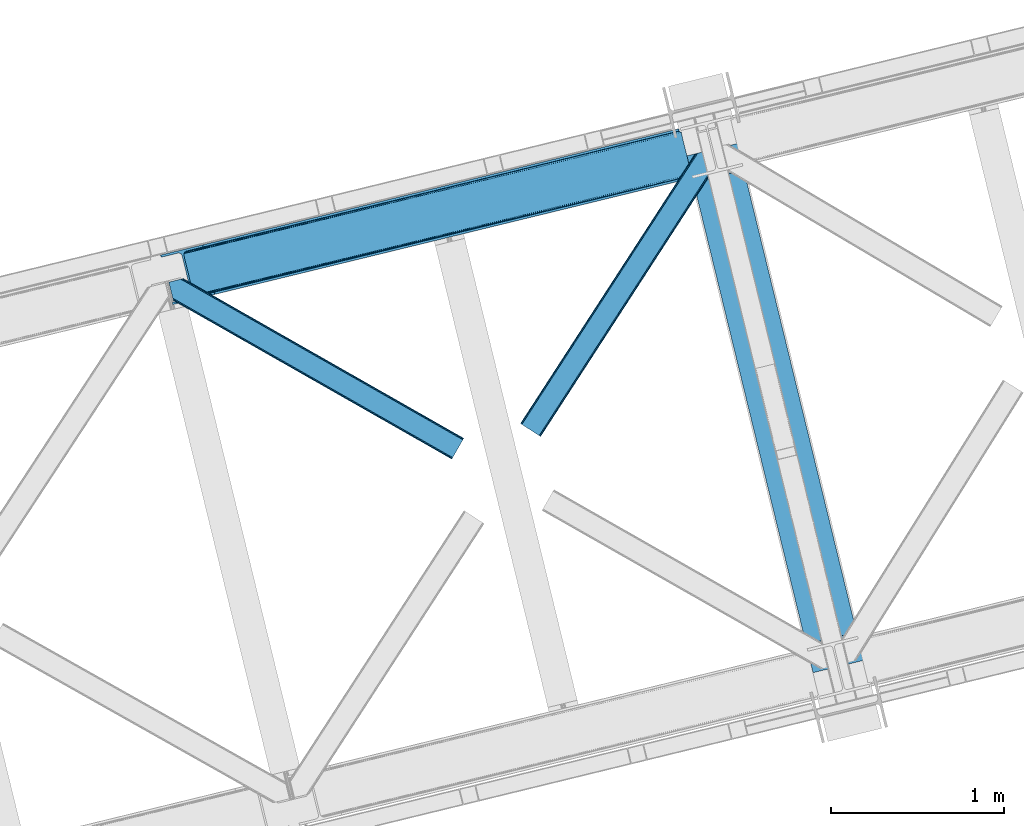
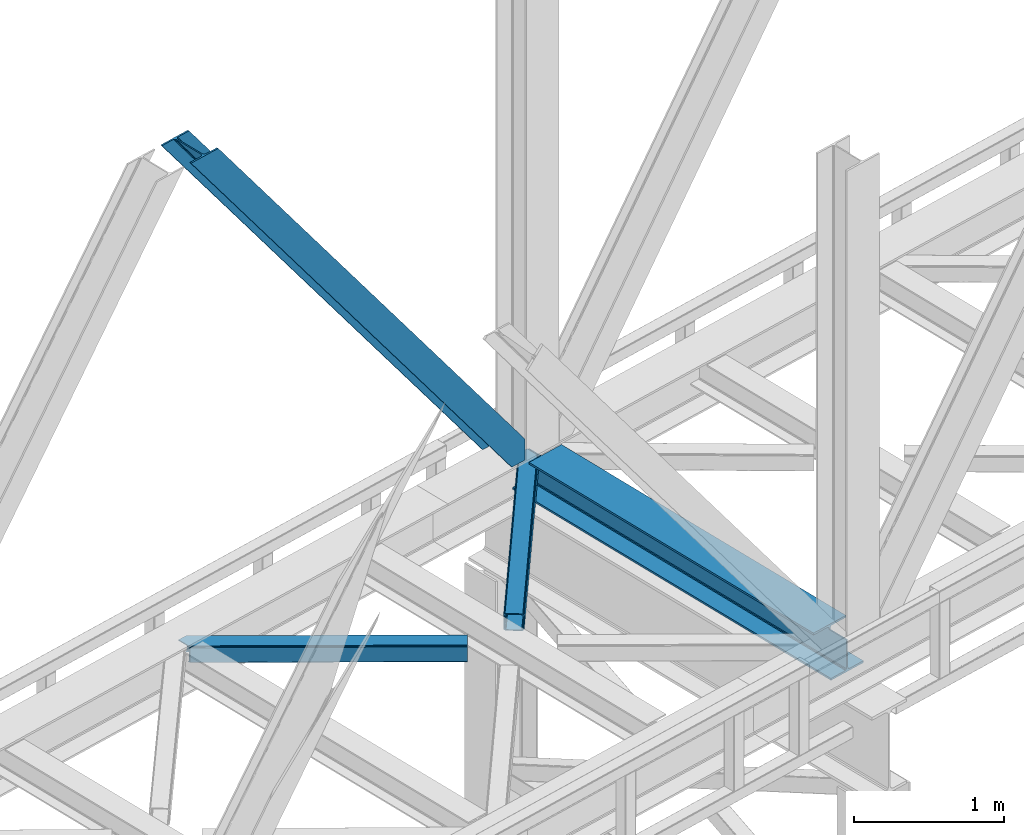
# One storey, part 55 of 93: 3 members, 1 beam.
"""IFC4 building model written with IfcOpenShell, lengths in millimetres."""

from ifc_helpers import new_model, entity, si_unit, converted_unit, derived_unit, direction, frame, origin, place, context, subcontext, project, spatial, triangles, polygons, material, type_object, element, save


model = new_model("IFC4")

# Units and contexts
model_context = context("Model", 3, precision=0.01, world=origin(), true_north=direction((6.12303176911189e-17, 1.0)))
plan_context = context("Plan", 3, precision=0.01, world=origin(), true_north=direction((6.12303176911189e-17, 1.0)))
body_context = subcontext(model_context, "Body", "Model", "MODEL_VIEW")
ifc_project = project(units=[si_unit("LENGTHUNIT", "METRE", prefix="MILLI"), si_unit("AREAUNIT", "SQUARE_METRE"), si_unit("VOLUMEUNIT", "CUBIC_METRE"), converted_unit("PLANEANGLEUNIT", "DEGREE", entity("IfcRatioMeasure", 0.0174532925199433), si_unit("PLANEANGLEUNIT", "RADIAN"), dimensions=[0, 0, 0, 0, 0, 0, 0]), si_unit("MASSUNIT", "GRAM", prefix="KILO"), derived_unit("MASSDENSITYUNIT", [(si_unit("MASSUNIT", "GRAM", prefix="KILO"), 1), (si_unit("LENGTHUNIT", "METRE"), -3)]), derived_unit("MOMENTOFINERTIAUNIT", [(si_unit("LENGTHUNIT", "METRE"), 4)]), si_unit("TIMEUNIT", "SECOND"), si_unit("FREQUENCYUNIT", "HERTZ"), si_unit("THERMODYNAMICTEMPERATUREUNIT", "DEGREE_CELSIUS"), derived_unit("THERMALTRANSMITTANCEUNIT", [(si_unit("MASSUNIT", "GRAM", prefix="KILO"), 1), (si_unit("THERMODYNAMICTEMPERATUREUNIT", "KELVIN"), -1), (si_unit("TIMEUNIT", "SECOND"), -3)]), derived_unit("VOLUMETRICFLOWRATEUNIT", [(si_unit("LENGTHUNIT", "METRE"), 3), (si_unit("TIMEUNIT", "SECOND"), -1)]), derived_unit("MASSFLOWRATEUNIT", [(si_unit("MASSUNIT", "GRAM", prefix="KILO"), 1), (si_unit("TIMEUNIT", "SECOND"), -1)]), derived_unit("ROTATIONALFREQUENCYUNIT", [(si_unit("TIMEUNIT", "SECOND"), -1)]), si_unit("ELECTRICCURRENTUNIT", "AMPERE"), si_unit("ELECTRICVOLTAGEUNIT", "VOLT"), si_unit("POWERUNIT", "WATT"), si_unit("FORCEUNIT", "NEWTON", prefix="KILO"), si_unit("ILLUMINANCEUNIT", "LUX"), si_unit("LUMINOUSFLUXUNIT", "LUMEN"), si_unit("LUMINOUSINTENSITYUNIT", "CANDELA"), derived_unit("USERDEFINED", [(si_unit("MASSUNIT", "GRAM", prefix="KILO"), -1), (si_unit("LENGTHUNIT", "METRE"), -2), (si_unit("TIMEUNIT", "SECOND"), 3), (si_unit("LUMINOUSFLUXUNIT", "LUMEN"), 1)]), derived_unit("LINEARVELOCITYUNIT", [(si_unit("LENGTHUNIT", "METRE"), 1), (si_unit("TIMEUNIT", "SECOND"), -1)]), si_unit("PRESSUREUNIT", "PASCAL"), derived_unit("USERDEFINED", [(si_unit("LENGTHUNIT", "METRE"), -2), (si_unit("MASSUNIT", "GRAM", prefix="KILO"), 1), (si_unit("TIMEUNIT", "SECOND"), -2)]), derived_unit("LINEARFORCEUNIT", [(si_unit("MASSUNIT", "GRAM", prefix="KILO"), 1), (si_unit("LENGTHUNIT", "METRE"), 1), (si_unit("TIMEUNIT", "SECOND"), -2), (si_unit("LENGTHUNIT", "METRE"), -1)]), derived_unit("PLANARFORCEUNIT", [(si_unit("MASSUNIT", "GRAM", prefix="KILO"), 1), (si_unit("LENGTHUNIT", "METRE"), 1), (si_unit("TIMEUNIT", "SECOND"), -2), (si_unit("LENGTHUNIT", "METRE"), -2)])], contexts=[model_context, plan_context])

# Site, building, storey
site_placement = place(None, origin())
site = spatial("IfcSite", under=ifc_project, at=site_placement, CompositionType="ELEMENT")
building_placement = place(site_placement, origin())
building = spatial("IfcBuilding", under=site, at=building_placement, CompositionType="ELEMENT")
storey_placement = place(building_placement, frame((0.0, 0.0, 15900.0)))
storey = spatial("IfcBuildingStorey", under=building, at=storey_placement, CompositionType="ELEMENT", Elevation=15900.0)

# Beam
ifc_material = material(Name="Metal painted (White)")
beam_type = type_object("IfcBeamType", PredefinedType="BEAM")
beam_placement = place(storey_placement, frame((-30305.029649813, 10399.0136460871, 3385.0)))
element("IfcBeam", 1, at=beam_placement, inside=storey, type_object=beam_type, material=ifc_material, ObjectType="Steel Beam", PredefinedType="BEAM", context=body_context, shape_type="Tessellation", body=[
    polygons([(1020.29791862021, 71.0478278971064, 15.4999999999986), (1020.29791862021, 71.0478278971043, 0.0), (291.465617442446, 3060.99928682749, 0.0), (291.465617442446, 3060.99928682749, 15.4999999999986), (896.910807236245, 40.9709140873313, 15.4999999999986), (168.078506058478, 3030.92237301772, 15.4999999999986), (890.218463462283, 39.3395844888286, 16.8701684147963), (161.386162284524, 3029.29104341922, 16.8701684147963), (884.544968361671, 37.9566100336562, 20.7720779386413), (155.712667183908, 3027.90806896404, 20.7720779386413), (880.754060133096, 37.0325360459227, 26.6116982174316), (151.921758955333, 3026.98399497631, 26.6116982174316), (879.4228701897, 36.7080444135051, 33.500000000001), (150.590569011932, 3026.65950334389, 33.500000000001), (140.875048430518, 3024.29124241399, 33.500000000001), (140.875048430518, 3024.29124241399, 259.000000000002), (150.590569011932, 3026.65950334389, 259.000000000002), (-4.33146851719357e-12, 2989.95145893039, 0.0), (4.33146851719357e-12, 2989.95145893039, 15.4999999999986), (123.387111383968, 3020.02837274016, 15.4999999999986), (130.079455157931, 3021.65970233866, 16.8701684147963), (135.752950258555, 3023.04267679384, 20.7720779386413), (139.543858487122, 3023.96675078157, 26.6116982174294), (879.422870189691, 36.7080444135029, 259.000000000002), (869.707349608281, 34.3397834836035, 259.000000000002), (869.707349608281, 34.3397834836035, 33.500000000001), (868.376159664884, 34.0152918511859, 26.6116982174294), (864.585251436314, 33.0912178634524, 20.7720779386413), (858.911756335698, 31.70824340828, 16.8701684147963), (852.219412561735, 30.0769138097752, 15.4999999999986), (728.832301177763, 4.33146851719357e-12, 15.4999999999986), (728.832301177763, 2.16573425859679e-12, 0.0), (839.723099749336, 199.571930111233, 259.069791776412), (188.068298227652, 2872.911390143, 259.000000000002), (188.291691329505, 2871.99494573803, 259.61730333112), (188.304080173131, 2871.94412150426, 266.500003008253), (839.577920935828, 200.167408132524, 266.500002998871), (839.578271056585, 200.16597182779, 260.000004007589), (830.098162468533, 196.83185809429, 259.006343172366), (829.874792453796, 197.748309612736, 259.61730333112), (829.862403610166, 197.799133846509, 266.500003008253), (178.588562847473, 2869.57584721824, 266.500002998871), (178.588212726721, 2869.57728352298, 260.000004007589), (178.443407068381, 2870.17133233677, 259.07612046749), (178.352777646237, 2870.5431292131, 259.000000000002), (840.909408805755, 200.49067757721, 273.388305639783), (844.699685394451, 201.417342749125, 279.227924098781), (850.372756341981, 202.802057212801, 283.129832400615), (857.064948023115, 204.434010743614, 284.500000377228), (980.451976710959, 234.511263798723, 284.500000138971), (980.450306904298, 234.518113867457, 299.999995328161), (688.984884807028, 163.469484603413, 299.999995890962), (688.986554613684, 163.462634534683, 284.500000701776), (812.373583301532, 193.539887589794, 284.500000463519), (819.066070197671, 195.170630056372, 283.129832461069), (824.739981846431, 196.551895700901, 279.227924137322), (828.531516633423, 197.473399350195, 273.388305663684), (177.257074977542, 2869.25257777356, 273.388305639788), (173.46679838885, 2868.32591260164, 279.227924098781), (167.79372744132, 2866.94119813797, 283.129832400619), (161.101535760187, 2865.30924460715, 284.500000377228), (37.7145070723384, 2835.23199155204, 284.500000138971), (37.7161768789945, 2835.22514148331, 299.999995328161), (329.181598976269, 2906.27377074735, 299.999995890962), (329.179929169613, 2906.28062081608, 284.500000701776), (205.792900481765, 2876.20336776097, 284.500000463519), (199.10041358563, 2874.57262529439, 283.129832461065), (193.42650193687, 2873.19135964987, 279.227924137322), (189.634967149874, 2872.26985600057, 273.388305663684)], [[[1, 2, 3, 4]], [[5, 1, 4, 6]], [[7, 5, 6, 8]], [[9, 7, 8, 10]], [[11, 9, 10, 12]], [[13, 11, 12, 14]], [[15, 16, 17, 14, 12, 10, 8, 6, 4, 3, 18, 19, 20, 21, 22, 23]], [[13, 24, 25, 26, 27, 28, 29, 30, 31, 32, 2, 1, 5, 7, 9, 11]], [[2, 32, 18, 3]], [[32, 31, 19, 18]], [[31, 30, 20, 19]], [[27, 26, 15, 23]], [[28, 27, 23, 22]], [[29, 28, 22, 21]], [[30, 29, 21, 20]], [[33, 24, 13, 14, 17, 34, 35, 36, 37, 38]], [[25, 39, 40, 41, 42, 43, 44, 16, 15, 26]], [[39, 25, 24, 33]], [[45, 34, 17, 16]], [[41, 40, 38, 37, 46, 47, 48, 49, 50, 51, 52, 53, 54, 55, 56, 57]], [[42, 58, 59, 60, 61, 62, 63, 64, 65, 66, 67, 68, 69, 36, 35, 43]], [[46, 37, 36, 69]], [[47, 46, 69, 68]], [[48, 47, 68, 67]], [[49, 48, 67, 66]], [[50, 49, 66, 65]], [[51, 50, 65, 64]], [[52, 51, 64, 63]], [[53, 52, 63, 62]], [[54, 53, 62, 61]], [[55, 54, 61, 60]], [[56, 55, 60, 59]], [[57, 56, 59, 58]], [[41, 57, 58, 42]]], closed=False),
])

# Members
member_type_1 = type_object("IfcMemberType", PredefinedType="BRACE")
member_1_placement = place(storey_placement, frame((-33350.0550476074, 12528.1294830322, 3694.99929199219)))
element("IfcMember", 2, at=member_1_placement, inside=storey, type_object=member_type_1, ObjectType="Steel Vertical Brace", PredefinedType="BRACE", context=body_context, shape_type="Tessellation", body=[
    triangles([(3070.87069702148, 756.345693969726, 0.827856445310317), (3071.52647094726, 755.358544921874, 1.13481445312209), (3070.1056274414, 754.873690795897, 0.0), (3068.17783813476, 762.779022216797, 0.0), (3067.78018798828, 753.547027587891, 7.26932373046657), (3067.78018798828, 753.547027587891, 0.0), (3064.92454833984, 750.387918090819, 0.0), (3063.4827758789, 746.380023193358, 0.0), (3065.22220458984, 750.173977661132, 14.9735046386704), (3064.09204101562, 748.682208251952, 18.377947998044), (3063.66881103515, 742.123306274414, 0.0), (3063.35952758789, 744.488278198241, 30.2981506347642), (3063.478125, 743.106967163085, 41.9881347656228), (3063.68508911132, 746.346304321289, 25.0194030761704), (3063.478125, 743.106967163085, 170.743066406249), (3063.66881103515, 742.123306274414, 170.803527832031), (215.791479492182, 48.952825927734, 3911.00081176758), (310.557788085935, 72.0537414550781, 3911.00081176758), (192.89055175781, 54.8071197509762, 3911.00081176758), (199.02971191406, 50.2934417724609, 3911.00081176758), (207.071081542963, 48.2377532958981, 3911.00081176758), (189.588427734372, 61.092782592772, 3911.00081176758), (3066.51049804687, 730.465878295898, 170.803527832031), (313.636669921871, 59.4231170654293, 3911.00081176758), (3066.51049804687, 730.465878295898, 0.0), (2948.45258789062, 701.687402343749, 0.0), (69.8631774902315, 0.0, 3911.00081176758), (2945.37370605468, 714.318026733397, 0.0), (66.7842956542954, 12.630624389647, 3911.00081176758), (161.552929687496, 35.7315399169911, 3911.00081176758), (3040.14001464843, 737.417779541014, 0.0), (3057.81567993164, 760.253594970702, 0.0), (3057.77847290039, 753.154028320312, 0.0), (179.2285949707, 58.5673553466786, 3911.00081176758), (179.191387939449, 51.4677886962891, 3911.00081176758), (3054.4042602539, 746.32188720703, 0.0), (175.817175292963, 44.6356475830071, 3911.00081176758), (3048.21161499023, 740.795480346678, 0.0), (169.622204589839, 39.1092407226552, 3911.00081176758), (3002.63532714843, 986.624661254882, 0.0), (124.048242187499, 284.938421630859, 3911.00081176758), (2976.43227539062, 998.764617919922, 0.0), (2985.15499877929, 999.480853271483, 0.0), (106.5655883789, 297.79461364746, 3911.00081176758), (97.8451904296817, 297.078378295897, 3911.00081176758), (2993.1963684082, 997.42516479492, 0.0), (114.609283447266, 295.738925170897, 3911.00081176758), (2999.33552856445, 992.91032409668, 0.0), (120.748443603516, 291.224084472655, 3911.00081176758), (3.07888183593604, 273.97862548828, 3911.00081176758), (2881.66829223633, 975.664865112303, 0.0), (2878.58941040039, 988.295489501952, 0.0), (0.0, 286.608087158202, 3911.00081176758), (3012.99748535156, 989.151251220703, 0.0), (134.40807495117, 287.463848876952, 3911.00081176758), (144.014465332031, 306.921963500976, 3911.00081176758), (243.773492431639, 346.031204223633, 3911.00081176758), (152.083740234375, 310.29966430664, 3911.00081176758), (137.821820068355, 301.396719360351, 3911.00081176758), (134.447607421869, 294.564578247069, 3911.00081176758), (246.852374267575, 333.400579833984, 3911.00081176758), (2996.64732055664, 1017.07280273437, 170.803527832031), (2996.64732055664, 1017.07280273437, 0.0), (2999.48900756836, 1005.41421203613, 170.803527832031), (2999.77271118164, 1004.45380554199, 170.743066406249), (2999.77271118164, 1004.45380554199, 41.9881347656228), (2999.48900756836, 1005.41421203613, 0.0), (3008.39544067383, 997.164715576171, 0.0), (3001.28192138672, 1001.54933166504, 0.0), (3004.40731201172, 998.655322265624, 0.0), (3011.06969604492, 997.055419921875, 0.0), (3000.30291137695, 1003.17248840332, 30.2981506347642), (3001.44470214843, 1001.67257995605, 25.0194030761704), (3002.88182373047, 999.785485839842, 18.377947998044), (3004.57474365234, 998.982046508789, 14.9735046386704), (3008.39544067383, 997.164715576171, 7.26932373046657), (3012.55565185547, 997.2798248291, 1.13481445312209), (3012.42775268554, 996.101989746094, 0.827856445310317)], [[1, 2, 3], [3, 4, 1], [5, 6, 3], [7, 6, 5], [8, 7, 9], [9, 10, 8], [11, 12, 13], [11, 8, 14], [14, 12, 11], [13, 15, 16], [16, 11, 13], [10, 14, 8], [5, 9, 7], [3, 2, 5], [17, 18, 15], [15, 13, 17], [1, 19, 5], [19, 20, 10], [10, 9, 19], [9, 5, 19], [13, 12, 21], [21, 17, 13], [14, 20, 12], [14, 10, 20], [20, 21, 12], [5, 2, 1], [1, 4, 19], [22, 19, 4], [16, 15, 18], [23, 16, 24], [18, 24, 16], [23, 25, 16], [11, 16, 25], [24, 26, 23], [24, 27, 26], [26, 25, 23], [28, 26, 29], [27, 29, 26], [29, 30, 28], [31, 28, 30], [32, 33, 34], [35, 34, 33], [33, 36, 35], [37, 35, 36], [36, 38, 37], [39, 37, 38], [38, 31, 39], [30, 39, 31], [40, 32, 41], [34, 41, 32], [42, 43, 44], [44, 45, 42], [43, 46, 47], [47, 44, 43], [46, 48, 49], [49, 47, 46], [48, 40, 41], [41, 49, 48], [45, 50, 51], [51, 42, 45], [52, 51, 50], [50, 53, 52], [4, 54, 22], [55, 22, 54], [41, 34, 55], [37, 39, 21], [30, 27, 24], [29, 27, 30], [39, 30, 17], [34, 35, 19], [35, 37, 20], [47, 56, 44], [53, 45, 57], [45, 44, 58], [53, 50, 45], [47, 49, 59], [49, 41, 60], [55, 34, 22], [17, 21, 39], [19, 35, 20], [21, 20, 37], [19, 22, 34], [24, 17, 30], [24, 18, 17], [58, 44, 56], [59, 49, 60], [55, 60, 41], [59, 56, 47], [58, 57, 45], [57, 58, 61], [57, 52, 53], [52, 57, 62], [63, 52, 62], [64, 62, 57], [65, 64, 61], [57, 61, 64], [61, 58, 65], [66, 65, 58], [64, 67, 63], [63, 62, 64], [32, 40, 54], [46, 43, 67], [42, 52, 63], [51, 52, 42], [43, 42, 63], [40, 48, 68], [48, 46, 69], [36, 11, 38], [26, 31, 25], [31, 38, 25], [26, 28, 31], [36, 33, 8], [33, 32, 6], [8, 11, 36], [54, 40, 68], [67, 69, 46], [63, 67, 43], [48, 69, 70], [70, 68, 48], [71, 54, 68], [32, 54, 4], [8, 33, 7], [33, 6, 7], [11, 25, 38], [32, 4, 6], [3, 6, 4], [67, 72, 73], [65, 66, 64], [67, 64, 66], [66, 72, 67], [69, 74, 75], [69, 73, 74], [70, 75, 76], [76, 77, 71], [71, 68, 76], [76, 68, 70], [75, 70, 69], [73, 69, 67], [60, 78, 76], [76, 59, 60], [76, 75, 59], [74, 59, 75], [78, 77, 76], [54, 78, 60], [60, 55, 54], [73, 59, 74], [59, 73, 72], [56, 59, 72], [72, 66, 56], [58, 56, 66], [77, 78, 71], [54, 71, 78]]),
])
member_type_2 = type_object("IfcMemberType", PredefinedType="BRACE")
member_2_placement = place(storey_placement, frame((-31269.0378845215, 11764.6853851318, 3510.57682800293)))
element("IfcMember", 3, at=member_2_placement, inside=storey, type_object=member_type_2, ObjectType="Steel Horizontal Brace", PredefinedType="BRACE", context=body_context, shape_type="Tessellation", body=[
    triangles([(972.968518066409, 1545.29288635254, 0.386022949220205), (1007.16875610352, 1404.99563598633, 0.363931274416245), (14.7014282226592, 66.6447692871097, 0.0), (102.814654541016, 9.54011535644531, 0.0), (1.13248901367479, 75.4349304199222, 10.8028289794929), (0.011627197265625, 76.1581420898438, 17.5000946044929), (1010.67784423828, 1635.6559753418, 17.9070465087898), (968.503674316409, 1566.80901489258, 9.68196716308739), (4.31601562500146, 73.3734283447266, 5.12526855468968), (968.640875244142, 1567.26712646485, 9.92381286621094), (968.357171630862, 1566.32067260742, 9.42384338378906), (968.210668945314, 1565.83116760254, 9.16455688476708), (968.073468017581, 1565.37421875, 8.92387390136719), (968.938531494143, 1561.82676086426, 5.51361694336083), (1012.94282226563, 1636.20826721191, 11.2760559082053), (1013.40325927734, 1636.32105102539, 9.92381286621094), (970.787255859377, 1554.24117736817, 1.71966247558521), (9.07851562500218, 70.2864074707031, 1.33131408691406), (1010.67784423828, 1635.6559753418, 122.907614135744), (0.0, 76.1395385742198, 122.500662231447), (1012.56145019531, 1636.11524963379, 129.604879760744), (1.11853637695458, 75.4140014648438, 129.195602416992), (1017.92856445313, 1637.42330932617, 135.283602905274), (4.29973754883031, 73.3490112304698, 134.874325561523), (1025.96528320313, 1639.38249206543, 139.076394653323), (9.06456298828198, 70.2608276367191, 138.667117309571), (1035.44377441406, 1641.69281616211, 140.411196899415), (14.6828247070334, 66.6191894531257, 139.999594116212), (973.040606689454, 1549.21939086914, 9.92381286621094), (972.796435546876, 1548.6089630127, 9.84707336425708), (972.833642578127, 1547.58344421387, 9.54011535644531), (972.87317504883, 1546.54862365723, 9.23083190917896), (972.912707519532, 1545.5231048584, 8.92387390136719), (1032.56255493164, 1640.99053344727, 9.92381286621094), (14.9525756835938, 66.4773376464855, 8.3320495605476), (20.5754882812507, 62.8368621826176, 6.99957275390625), (975.249774169923, 1535.93996887207, 7.38443298339917), (10.1877502441421, 69.5655212402344, 12.1248413085959), (1027.83726196289, 1639.83827819824, 12.535281372071), (973.075488281251, 1544.85570373535, 8.81574096679833), (1022.46782226563, 1638.53021850586, 18.2116790771506), (1020.58421630859, 1638.07094421387, 24.9089447021506), (7.00422363281541, 71.6270233154301, 17.8024017333992), (5.88568725586083, 72.3502349853516, 24.4996673583992), (1004.8875, 1414.3485534668, 7.36582946777344), (96.9382690429702, 13.3456970214847, 6.99957275390625), (1007.06178588867, 1405.4363067627, 8.80411376953271), (1007.24084472656, 1404.70030517578, 8.92387390136719), (1012.06845703125, 1384.89221191406, 8.92387390136719), (1011.19874267578, 1388.46176147461, 5.48687438964771), (1009.35001831055, 1396.0473449707, 1.69524536133031), (1020.58421630859, 1638.07094421387, 115.908041381837), (5.87638549804979, 72.3339569091804, 115.498764038086), (1035.87398071289, 1641.7974609375, 132.079147338867), (1045.34782104492, 1644.10778503418, 133.411624145509), (20.5592102050796, 62.8124450683608, 133.000021362306), (14.9386230468772, 66.4552459716797, 131.667544555665), (1027.83726196289, 1639.83827819824, 128.284030151368), (10.1737976074219, 69.5434295654304, 127.874752807616), (1022.46782226563, 1638.53021850586, 122.605307006837), (6.99259643554979, 71.6084197998061, 122.196029663086), (1095.16803588867, 1656.2512298584, 140.420498657226), (1095.16803588867, 1656.2512298584, 133.42092590332), (1115.62260131836, 1572.34239807129, 140.40887145996), (102.798376464845, 9.5145355224613, 139.999594116212), (1113.34134521485, 1581.69647827149, 133.409298706054), (96.92431640625, 13.3224426269535, 133.000021362306), (1117.80153808594, 1563.39526977539, 139.074069213868), (108.418963623048, 5.87289733886792, 138.667117309571), (1119.65258789063, 1555.80852355957, 135.278952026369), (113.181463623048, 2.78587646484448, 134.874325561523), (1120.88739624024, 1550.74022827148, 129.602554321289), (116.36731567383, 0.72321166992333, 129.195602416992), (1121.32225341797, 1548.96010437012, 122.905288696289), (117.485852050784, 0.0, 122.500662231447), (1121.32225341797, 1548.96010437012, 17.9047210693352), (117.499804687501, 0.0197662353530177, 17.5000946044929), (107.309729003908, 6.59378356933667, 127.874752807616), (110.495581054689, 4.53228149414099, 122.196029663086), (111.611791992189, 3.80790710449219, 115.498764038086), (102.544903564456, 9.6808044433601, 131.667544555665), (116.38126831055, 0.74530334472729, 10.8028289794929), (107.323681640628, 6.61471252441515, 12.1248413085959), (113.197741699219, 2.80913085937573, 5.12526855468968), (111.623419189455, 3.82534790039063, 24.4996673583992), (110.507208251955, 4.55088500976672, 17.8024017333992), (108.432916259768, 5.89731445312646, 1.33131408691406), (102.558856201173, 9.70289611816406, 8.3320495605476), (1118.60846557617, 1560.09314575195, 122.602981567383), (1119.04099731446, 1558.31302185059, 115.905715942383), (1117.37133178711, 1565.16260375977, 128.281704711913), (1115.52260742188, 1572.74818725586, 132.076821899416), (1119.04099731446, 1558.31302185059, 24.9054565429688), (1118.60846557617, 1560.09314575195, 18.209353637696), (1120.69438476563, 1551.53436584473, 9.92381286621094), (1117.37133178711, 1565.16260375977, 12.5329559326165), (1120.79902954102, 1551.09834594727, 11.2725677490234), (1116.2853515625, 1569.61698303223, 9.92381286621094), (1012.19868164063, 1384.68524780274, 9.30640869140552), (1012.7358581543, 1385.10731506348, 9.72266235351708), (1012.99630737305, 1385.31079101563, 9.92381286621094), (1008.6035522461, 1403.32829589844, 9.92381286621094), (1007.57570800781, 1403.93872375488, 9.27734069824146)], [[1, 2, 3], [4, 3, 2], [5, 6, 7], [8, 9, 10], [9, 8, 11], [12, 9, 11], [9, 12, 13], [13, 14, 9], [5, 15, 10], [10, 9, 5], [15, 16, 10], [17, 1, 18], [3, 18, 1], [14, 17, 9], [18, 9, 17], [7, 15, 5], [19, 7, 20], [6, 20, 7], [21, 19, 22], [20, 22, 19], [23, 21, 24], [22, 24, 21], [25, 23, 26], [24, 26, 23], [27, 25, 28], [26, 28, 25], [8, 10, 29], [11, 8, 30], [12, 11, 31], [13, 12, 32], [32, 33, 13], [31, 32, 12], [30, 31, 11], [29, 30, 8], [16, 34, 29], [29, 10, 16], [35, 36, 37], [38, 30, 29], [29, 39, 38], [29, 34, 39], [38, 35, 40], [40, 33, 38], [31, 38, 32], [31, 30, 38], [38, 33, 32], [37, 40, 35], [41, 42, 43], [44, 43, 42], [39, 41, 38], [43, 38, 41], [45, 37, 36], [36, 46, 45], [1, 37, 45], [13, 33, 14], [33, 40, 1], [37, 1, 40], [33, 17, 14], [33, 1, 17], [2, 1, 45], [2, 45, 47], [48, 2, 47], [49, 50, 48], [48, 51, 2], [48, 50, 51], [42, 52, 53], [53, 44, 42], [54, 55, 56], [56, 57, 54], [58, 54, 57], [57, 59, 58], [60, 58, 59], [59, 61, 60], [52, 60, 61], [61, 53, 52], [60, 19, 21], [54, 25, 27], [62, 55, 27], [55, 62, 63], [55, 54, 27], [58, 25, 54], [58, 60, 23], [23, 25, 58], [21, 23, 60], [42, 7, 19], [39, 16, 41], [60, 52, 19], [39, 34, 16], [42, 41, 7], [52, 42, 19], [15, 7, 41], [41, 16, 15], [64, 27, 28], [27, 64, 62], [28, 65, 64], [55, 66, 56], [55, 63, 66], [67, 56, 66], [68, 64, 65], [65, 69, 68], [70, 68, 69], [69, 71, 70], [72, 70, 71], [71, 73, 72], [74, 72, 73], [73, 75, 74], [76, 74, 75], [75, 77, 76], [73, 78, 79], [80, 77, 75], [73, 79, 75], [73, 71, 78], [79, 80, 75], [78, 71, 69], [67, 65, 28], [65, 81, 69], [81, 65, 67], [81, 78, 69], [82, 83, 84], [85, 77, 80], [77, 86, 82], [86, 77, 85], [82, 86, 83], [4, 46, 3], [87, 84, 83], [83, 88, 87], [88, 46, 4], [4, 87, 88], [59, 26, 24], [28, 56, 67], [28, 57, 56], [57, 28, 26], [59, 57, 26], [53, 20, 6], [22, 61, 59], [24, 22, 59], [61, 22, 20], [53, 61, 20], [18, 38, 9], [3, 46, 36], [36, 35, 3], [35, 38, 18], [18, 3, 35], [5, 9, 38], [6, 44, 53], [43, 6, 5], [6, 43, 44], [43, 5, 38], [89, 90, 79], [80, 79, 90], [91, 89, 78], [79, 78, 89], [92, 91, 81], [78, 81, 91], [66, 92, 67], [81, 67, 92], [90, 93, 80], [85, 80, 93], [94, 95, 96], [93, 74, 76], [76, 97, 94], [97, 95, 94], [94, 93, 76], [90, 74, 93], [89, 91, 70], [72, 89, 70], [72, 74, 89], [90, 89, 74], [91, 68, 70], [92, 68, 91], [98, 96, 95], [92, 66, 64], [92, 64, 68], [66, 62, 64], [66, 63, 62], [82, 97, 76], [82, 99, 100], [101, 97, 82], [101, 95, 97], [84, 50, 99], [99, 82, 84], [51, 50, 87], [84, 87, 50], [2, 51, 4], [87, 4, 51], [76, 77, 82], [102, 103, 88], [48, 88, 103], [83, 96, 102], [102, 88, 83], [96, 98, 102], [46, 88, 48], [48, 45, 46], [94, 96, 83], [83, 86, 94], [93, 94, 86], [86, 85, 93], [99, 48, 103], [99, 103, 102], [98, 95, 102], [101, 102, 95]]),
])
member_type_3 = type_object("IfcMemberType", PredefinedType="BRACE")
member_3_placement = place(storey_placement, frame((-33302.3207519531, 11633.9363891602, 3510.57682800293)))
element("IfcMember", 4, at=member_3_placement, inside=storey, type_object=member_type_3, ObjectType="Steel Horizontal Brace", PredefinedType="BRACE", context=body_context, shape_type="Tessellation", body=[
    triangles([(1706.21445922852, 121.662341308593, 122.500662231447), (1706.19353027344, 121.673968505858, 17.5000946044929), (84.490191650395, 1045.00249328613, 17.9093719482444), (84.490191650395, 1045.00249328613, 122.909939575195), (1697.55917358398, 106.45280456543, 139.999594116212), (1700.87059936524, 112.2733795166, 138.667117309571), (69.2027526855454, 1041.2759765625, 139.078720092773), (59.7242614746137, 1038.96565246582, 140.413522338869), (1703.67973022461, 117.206799316406, 134.874325561523), (77.2371459960923, 1043.23399658203, 135.285928344729), (1705.55635986328, 120.504272460938, 129.197927856447), (82.6065856933637, 1044.54321899414, 129.607205200195), (20.454565429689, 940.498406982422, 140.411196899415), (1645.60653076172, 15.2060485839847, 139.999594116212), (0.0, 1024.40723876953, 140.42282409668), (1636.94426879883, 0.0, 122.500662231447), (1637.60701904297, 1.15806884765516, 129.197927856447), (26.1542175292998, 917.11611328125, 122.907614135744), (25.7193603515625, 918.896237182616, 129.604879760744), (1639.48364868164, 4.45321655273438, 134.874325561523), (24.4845520019517, 923.964532470703, 135.28127746582), (1642.29277954102, 9.38663635253943, 138.667117309571), (22.6358276367173, 931.551278686524, 139.076394653323), (1636.9256652832, 0.011627197265625, 17.5000946044929), (26.1542175292998, 917.11611328125, 17.9070465087898), (1705.5354309082, 120.517062377929, 10.8028289794929), (82.2252136230454, 1044.45020141602, 11.2783813476563), (153.281341552734, 1003.62943725586, 9.92613830566552), (1703.65647583008, 117.220751953124, 5.12643127441333), (155.520739746098, 998.663461303711, 5.51594238281177), (154.658001708987, 1002.20975646973, 8.92619934082177), (81.762451171875, 1044.33858032226, 9.92613830566552), (1700.84734497071, 112.288494873046, 1.33247680664135), (157.37178955078, 991.076715087891, 1.72198791503979), (1697.53359375, 106.467919921875, 0.0), (159.553051757815, 982.128424072265, 0.388348388671147), (1645.58095092774, 15.2211639404286, 0.0), (193.750964355473, 841.831173706054, 0.366256713867188), (157.68107299805, 985.581701660156, 9.92613830566552), (62.6054809570342, 1039.66793518066, 9.92613830566552), (159.657696533206, 981.692404174804, 8.81806640624927), (159.143774414064, 983.47601623535, 9.3087341308601), (158.657757568362, 984.173648071288, 9.51337280273583), (153.613879394536, 1003.28643493652, 9.68429260253833), (158.167089843751, 984.882907104491, 9.7203369140625), (1697.384765625, 106.203982543944, 8.3320495605476), (1700.19389648438, 111.137402343749, 12.1260040283196), (67.3307739257798, 1040.82019042969, 12.5376068115256), (161.831982421878, 972.775506591797, 7.38675842285375), (1694.0710144043, 100.384570312499, 7.00073547363354), (1702.0728515625, 114.433712768554, 17.8035644531265), (72.7002136230512, 1042.12825012207, 18.2140045166016), (1702.73095092774, 115.590618896484, 24.5008300781265), (74.5838195800825, 1042.58752441406, 24.9112701416016), (1702.74955444336, 115.580154418945, 115.501089477541), (74.5838195800825, 1042.58752441406, 115.910366821288), (67.3307739257798, 1040.82019042969, 128.286355590823), (59.2940551757856, 1038.86100769043, 132.081472778322), (72.7002136230512, 1042.12825012207, 122.607632446288), (49.8202148437485, 1036.55184631348, 133.416275024414), (0.0, 1024.40723876953, 133.423251342774), (1702.09378051758, 114.422085571288, 122.198355102541), (1700.21482543946, 111.124612426758, 127.874752807616), (1697.40802001953, 106.190029907226, 131.667544555665), (1694.09426879883, 100.370617675781, 133.000021362306), (18.1733093261719, 949.852487182618, 133.411624145509), (1649.07143554688, 21.2905609130848, 133.000021362306), (1649.04585571289, 21.3033508300778, 7.00073547363354), (191.472033691411, 851.184091186524, 7.36815490722802), (1642.94622802734, 10.5377288818363, 127.874752807616), (1645.75535888672, 15.4699859619141, 131.667544555665), (1640.40684814453, 6.08451232910193, 115.501089477541), (1641.06727294922, 7.24141845703161, 122.198355102541), (1642.26719970703, 9.40175170898328, 1.33247680664135), (1642.92297363281, 10.5493560791019, 12.1260040283196), (1639.45806884766, 4.46716918945276, 5.12643127441333), (1645.73210449219, 15.4839385986324, 8.3320495605476), (1637.58376464844, 1.17085876464807, 10.8028289794929), (1640.39057006836, 6.09381408691297, 24.5008300781265), (1641.0486694336, 7.25304565429724, 17.8035644531265), (20.3545715332075, 940.904196166992, 132.079147338867), (22.2032958984419, 933.318612670899, 128.284030151368), (23.4404296875, 928.249154663086, 122.605307006837), (23.8729614257827, 926.469030761718, 115.908041381837), (23.8729614257827, 926.469030761718, 24.9077819824233), (23.4404296875, 928.249154663086, 18.2116790771506), (22.2032958984419, 933.318612670899, 12.535281372071), (25.526348876956, 919.690374755859, 9.92613830566552), (25.6333190918012, 919.254354858398, 11.274893188478), (21.1173156738296, 937.772991943359, 9.92613830566552), (195.932226562501, 832.88288269043, 1.69757080078125), (193.643994140628, 842.271844482422, 8.80643920898365), (197.780950927736, 825.297299194335, 5.48919982910229), (198.650665283203, 821.727749633788, 8.92619934082177), (197.636773681639, 821.67310180664, 9.92613830566552), (193.244018554688, 839.690606689453, 9.92613830566552)], [[1, 2, 3], [3, 4, 1], [5, 6, 7], [7, 8, 5], [6, 9, 10], [10, 7, 6], [9, 11, 12], [12, 10, 9], [11, 1, 4], [4, 12, 11], [5, 13, 14], [13, 5, 8], [15, 13, 8], [16, 17, 18], [19, 18, 17], [17, 20, 19], [21, 19, 20], [20, 22, 21], [23, 21, 22], [22, 14, 23], [13, 23, 14], [24, 16, 25], [18, 25, 16], [26, 27, 3], [27, 26, 28], [26, 29, 30], [30, 31, 26], [31, 28, 26], [28, 32, 27], [29, 33, 34], [34, 30, 29], [33, 35, 36], [36, 34, 33], [3, 2, 26], [35, 37, 38], [38, 36, 35], [28, 39, 32], [40, 32, 39], [31, 41, 42], [31, 42, 43], [44, 43, 45], [44, 45, 39], [46, 42, 41], [43, 46, 45], [43, 42, 46], [39, 45, 46], [47, 48, 39], [39, 46, 47], [48, 40, 39], [46, 41, 49], [49, 50, 46], [47, 51, 52], [52, 48, 47], [51, 53, 54], [54, 52, 51], [53, 55, 54], [56, 54, 55], [57, 58, 7], [10, 57, 7], [10, 12, 59], [57, 10, 59], [59, 12, 4], [58, 8, 7], [15, 60, 61], [15, 8, 60], [58, 60, 8], [59, 4, 56], [54, 3, 52], [4, 54, 56], [3, 27, 52], [4, 3, 54], [32, 52, 27], [48, 52, 32], [40, 48, 32], [55, 62, 56], [59, 56, 62], [62, 63, 59], [57, 59, 63], [63, 64, 57], [58, 57, 64], [64, 65, 58], [60, 58, 65], [65, 66, 60], [65, 67, 66], [66, 61, 60], [68, 50, 69], [49, 69, 50], [11, 63, 62], [55, 2, 1], [11, 62, 1], [11, 9, 63], [62, 55, 1], [63, 9, 6], [65, 5, 14], [5, 64, 6], [64, 5, 65], [64, 63, 6], [26, 47, 29], [53, 2, 55], [2, 51, 26], [51, 2, 53], [26, 51, 47], [35, 50, 37], [33, 29, 47], [47, 46, 33], [46, 50, 35], [35, 33, 46], [70, 22, 20], [14, 67, 65], [14, 71, 67], [71, 14, 22], [70, 71, 22], [72, 16, 24], [17, 73, 70], [20, 17, 70], [73, 17, 16], [72, 73, 16], [74, 75, 76], [37, 50, 68], [68, 77, 37], [77, 75, 74], [74, 37, 77], [78, 76, 75], [24, 79, 72], [80, 24, 78], [24, 80, 79], [80, 78, 75], [67, 71, 81], [81, 66, 67], [71, 70, 82], [82, 81, 71], [70, 73, 83], [83, 82, 70], [73, 72, 84], [84, 83, 73], [72, 79, 85], [85, 84, 72], [83, 21, 82], [84, 85, 18], [19, 83, 18], [83, 19, 21], [83, 84, 18], [85, 25, 18], [86, 87, 88], [88, 89, 86], [89, 25, 86], [85, 86, 25], [66, 13, 15], [13, 81, 23], [81, 13, 66], [15, 61, 66], [81, 82, 23], [90, 88, 87], [23, 82, 21], [49, 36, 69], [34, 41, 30], [41, 34, 36], [30, 41, 31], [36, 49, 41], [69, 36, 38], [91, 92, 38], [92, 91, 93], [38, 92, 69], [93, 94, 92], [78, 24, 25], [76, 95, 94], [94, 93, 76], [78, 89, 95], [95, 76, 78], [89, 88, 95], [37, 74, 91], [91, 38, 37], [74, 76, 93], [93, 91, 74], [25, 89, 78], [68, 69, 92], [96, 87, 75], [96, 90, 87], [92, 75, 77], [92, 96, 75], [92, 77, 68], [79, 80, 85], [86, 85, 80], [80, 75, 86], [87, 86, 75], [96, 95, 88], [88, 90, 96]]),
])

save(model, "model.ifc")
